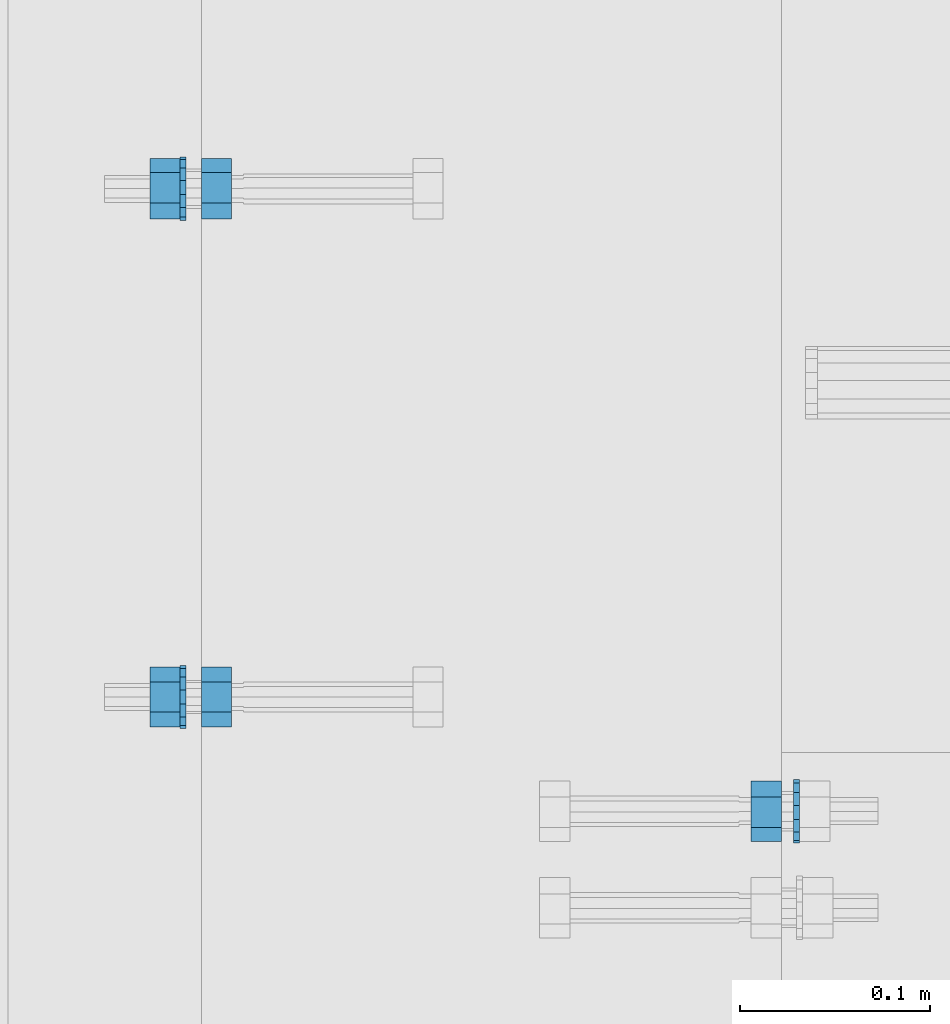
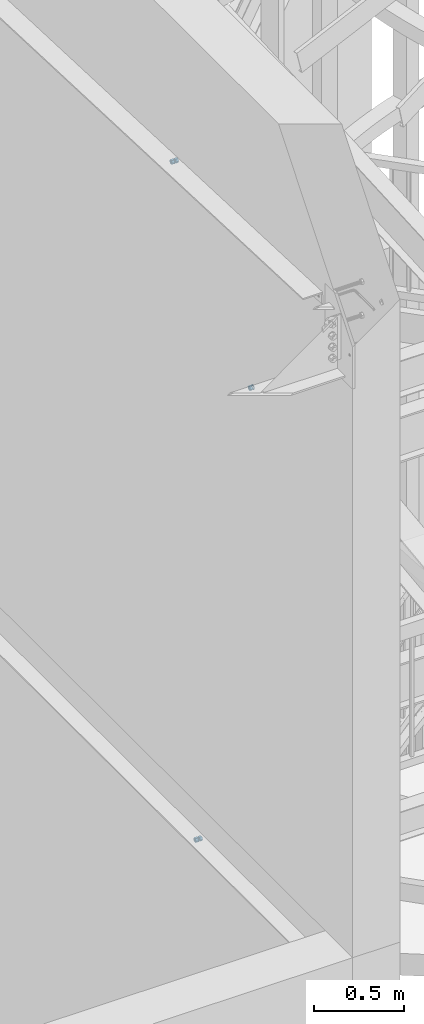
# One storey, part 641 of 975: 8 beams.
"""IFC2X3 building model written with IfcOpenShell, lengths in millimetres."""

from ifc_helpers import new_model, si_unit, frame, origin_with_axes, place, context, subcontext, project, spatial, faceted_brep, material, type_object, element, save


model = new_model("IFC2X3")

# Units and contexts
model_context = context("Model", 3, precision=1e-05, world=origin_with_axes())
body_context = subcontext(model_context, "Body", "Model", "MODEL_VIEW")
ifc_project = project(units=[si_unit("LENGTHUNIT", "METRE", prefix="MILLI"), si_unit("AREAUNIT", "SQUARE_METRE"), si_unit("VOLUMEUNIT", "CUBIC_METRE"), si_unit("MASSUNIT", "GRAM", prefix="KILO"), si_unit("TIMEUNIT", "SECOND"), si_unit("PLANEANGLEUNIT", "RADIAN"), si_unit("SOLIDANGLEUNIT", "STERADIAN"), si_unit("THERMODYNAMICTEMPERATUREUNIT", "DEGREE_CELSIUS"), si_unit("LUMINOUSINTENSITYUNIT", "LUMEN")], contexts=[model_context])

# Site, building, storey
site_placement = place(None, origin_with_axes())
site = spatial("IfcSite", under=ifc_project, at=site_placement, CompositionType="ELEMENT")
building_placement = place(site_placement, origin_with_axes())
building = spatial("IfcBuilding", under=site, at=building_placement, Name="Undefined", CompositionType="ELEMENT")
storey_placement = place(building_placement, origin_with_axes())
storey = spatial("IfcBuildingStorey", under=building, at=storey_placement, Name="Undefined", CompositionType="ELEMENT", Elevation=0.0)

# Beams
ifc_material_1 = material(Name="STEEL/F1554-36")
beam_type_1 = type_object("IfcBeamType", Name="5/8_HEAVY_HEX_NUT", PredefinedType="NOTDEFINED")
beam_1_placement = place(storey_placement, frame((29959.2998508932, 1654.53464347883, 6890.8904457363), z_axis=(3.96407267544419e-09, 0.0430877640020053, -0.999071291046494), x_axis=(-0.999999999999998, 6.90000001668524e-08, 0.0)))
element("IfcBeam", 1, at=beam_1_placement, inside=storey, type_object=beam_type_1, material=ifc_material_1, Name="HEADED_ANCHOR_BOLT", ObjectType="5/8_HEAVY_HEX_NUT", context=body_context, shape_type="Brep", body=[
    faceted_brep([(-1.09139364212751e-11, -15.8800001144436, -2.72848410531878e-12), (1.45519152283669e-11, -7.94000005722046, -13.7500000000036), (15.8750000000146, -7.94000005722137, -13.7500000000045), (15.8749999999891, -15.8800001144446, -2.72848410531878e-12), (2.91038304567337e-11, 7.94000005722319, -13.7500000000027), (15.8750000000291, 7.94000005722319, -13.7500000000027), (2.18278728425503e-11, 15.8800001144436, 9.09494701772928e-13), (15.8750000000218, 15.8800001144427, 9.09494701772928e-13), (-7.27595761418343e-12, 7.94000005722046, 13.7500000000027), (15.8749999999927, 7.94000005722046, 13.7500000000027), (-2.18278728425503e-11, -7.94000005722228, 13.7500000000009), (15.8749999999782, -7.94000005722319, 13.7500000000009), (-7.27595761418343e-12, 0.0, 8.72999954223724), (0.0, 3.78780484388062, 7.86545780435881), (15.875, 3.78780484387971, 7.86545780435881), (15.8749999999927, -9.09494701772928e-13, 8.72999954223724), (7.27595761418343e-12, 6.82538848405238, 5.44306568481716), (15.8750000000073, 6.82538848405238, 5.44306568481716), (1.09139364212751e-11, 8.51112022706275, 1.94260765157742), (15.8750000000109, 8.51112022706093, 1.94260765157651), (1.45519152283669e-11, 8.51112022706184, -1.94260765157651), (15.8750000000146, 8.51112022706184, -1.94260765157651), (2.18278728425503e-11, 6.8253884840542, -5.44306568481716), (15.8750000000218, 6.82538848405238, -5.44306568481716), (1.81898940354586e-11, 3.78780484388153, -7.86545780435881), (15.8750000000182, 3.78780484388062, -7.86545780435881), (1.81898940354586e-11, 9.09494701772928e-13, -8.72999954223997), (15.8750000000182, 9.09494701772928e-13, -8.72999954223997), (1.09139364212751e-11, -3.78780484387971, -7.86545780436063), (15.8750000000109, -3.78780484388062, -7.86545780436063), (3.63797880709171e-12, -6.82538848405238, -5.44306568481807), (15.8750000000036, -6.82538848405329, -5.44306568481807), (0.0, -8.51112022706184, -1.94260765157833), (15.875, -8.51112022706184, -1.94260765157833), (-7.27595761418343e-12, -8.51112022706184, 1.9426076515756), (15.8749999999927, -8.51112022706275, 1.9426076515756), (-1.09139364212751e-11, -6.82538848405329, 5.44306568481534), (15.8749999999927, -6.8253884840542, 5.44306568481534), (-7.27595761418343e-12, -3.78780484388062, 7.8654578043579), (15.8749999999927, -3.78780484388153, 7.8654578043579)], [[[0, 1, 2, 3]], [[1, 4, 5, 2]], [[4, 6, 7, 5]], [[6, 8, 9, 7]], [[8, 10, 11, 9]], [[10, 0, 3, 11]], [[12, 13, 14, 15]], [[13, 16, 17, 14]], [[16, 18, 19, 17]], [[18, 20, 21, 19]], [[20, 22, 23, 21]], [[22, 24, 25, 23]], [[24, 26, 27, 25]], [[26, 28, 29, 27]], [[28, 30, 31, 29]], [[30, 32, 33, 31]], [[32, 34, 35, 33]], [[34, 36, 37, 35]], [[36, 38, 39, 37]], [[38, 12, 15, 39]], [[5, 7, 9, 11, 3, 2], [17, 19, 21, 23, 25, 27, 29, 31, 33, 35, 37, 39, 15, 14]], [[10, 8, 6, 4, 1, 0], [38, 36, 34, 32, 30, 28, 26, 24, 22, 20, 18, 16, 13, 12]]]),
])
beam_2_placement = place(storey_placement, frame((29654.4998194947, 1981.48145341158, 8344.2911101487), z_axis=(-7.38476228434593e-09, 0.0401345820029659, 0.999194283073841), x_axis=(1.0, 0.0, 0.0)))
element("IfcBeam", 2, at=beam_2_placement, inside=storey, type_object=beam_type_1, material=ifc_material_1, Name="HEADED_ANCHOR_BOLT", ObjectType="5/8_HEAVY_HEX_NUT", context=body_context, shape_type="Brep", body=[
    faceted_brep([(-1.09139364212751e-11, -15.8800001144436, -2.72848410531878e-12), (1.45519152283669e-11, -7.94000005722046, -13.7500000000036), (15.8750000000146, -7.94000005722137, -13.7500000000045), (15.8749999999891, -15.8800001144446, -2.72848410531878e-12), (2.91038304567337e-11, 7.94000005722319, -13.7500000000027), (15.8750000000291, 7.94000005722319, -13.7500000000027), (2.18278728425503e-11, 15.8800001144436, 9.09494701772928e-13), (15.8750000000218, 15.8800001144427, 9.09494701772928e-13), (-7.27595761418343e-12, 7.94000005722046, 13.7500000000027), (15.8749999999927, 7.94000005722046, 13.7500000000027), (-2.18278728425503e-11, -7.94000005722228, 13.7500000000009), (15.8749999999782, -7.94000005722319, 13.7500000000009), (-7.27595761418343e-12, 0.0, 8.72999954223724), (0.0, 3.78780484388062, 7.86545780435881), (15.875, 3.78780484387971, 7.86545780435881), (15.8749999999927, -9.09494701772928e-13, 8.72999954223724), (7.27595761418343e-12, 6.82538848405238, 5.44306568481716), (15.8750000000073, 6.82538848405238, 5.44306568481716), (1.09139364212751e-11, 8.51112022706275, 1.94260765157742), (15.8750000000109, 8.51112022706093, 1.94260765157651), (1.45519152283669e-11, 8.51112022706184, -1.94260765157651), (15.8750000000146, 8.51112022706184, -1.94260765157651), (2.18278728425503e-11, 6.8253884840542, -5.44306568481716), (15.8750000000218, 6.82538848405238, -5.44306568481716), (1.81898940354586e-11, 3.78780484388153, -7.86545780435881), (15.8750000000182, 3.78780484388062, -7.86545780435881), (1.81898940354586e-11, 9.09494701772928e-13, -8.72999954223997), (15.8750000000182, 9.09494701772928e-13, -8.72999954223997), (1.09139364212751e-11, -3.78780484387971, -7.86545780436063), (15.8750000000109, -3.78780484388062, -7.86545780436063), (3.63797880709171e-12, -6.82538848405238, -5.44306568481807), (15.8750000000036, -6.82538848405329, -5.44306568481807), (0.0, -8.51112022706184, -1.94260765157833), (15.875, -8.51112022706184, -1.94260765157833), (-7.27595761418343e-12, -8.51112022706184, 1.9426076515756), (15.8749999999927, -8.51112022706275, 1.9426076515756), (-1.09139364212751e-11, -6.82538848405329, 5.44306568481534), (15.8749999999927, -6.8253884840542, 5.44306568481534), (-7.27595761418343e-12, -3.78780484388062, 7.8654578043579), (15.8749999999927, -3.78780484388153, 7.8654578043579)], [[[0, 1, 2, 3]], [[1, 4, 5, 2]], [[4, 6, 7, 5]], [[6, 8, 9, 7]], [[8, 10, 11, 9]], [[10, 0, 3, 11]], [[12, 13, 14, 15]], [[13, 16, 17, 14]], [[16, 18, 19, 17]], [[18, 20, 21, 19]], [[20, 22, 23, 21]], [[22, 24, 25, 23]], [[24, 26, 27, 25]], [[26, 28, 29, 27]], [[28, 30, 31, 29]], [[30, 32, 33, 31]], [[32, 34, 35, 33]], [[34, 36, 37, 35]], [[36, 38, 39, 37]], [[38, 12, 15, 39]], [[5, 7, 9, 11, 3, 2], [17, 19, 21, 23, 25, 27, 29, 31, 33, 35, 37, 39, 15, 14]], [[10, 8, 6, 4, 1, 0], [38, 36, 34, 32, 30, 28, 26, 24, 22, 20, 18, 16, 13, 12]]]),
])
beam_3_placement = place(storey_placement, frame((29627.5123194944, 1981.48144848359, 8344.29111018868), z_axis=(-7.38476228434593e-09, 0.0401345820029659, 0.999194283073841), x_axis=(1.0, 0.0, 0.0)))
element("IfcBeam", 3, at=beam_3_placement, inside=storey, type_object=beam_type_1, material=ifc_material_1, Name="HEADED_ANCHOR_BOLT", ObjectType="5/8_HEAVY_HEX_NUT", context=body_context, shape_type="Brep", body=[
    faceted_brep([(-1.09139364212751e-11, -15.8800001144436, -2.72848410531878e-12), (1.45519152283669e-11, -7.94000005722046, -13.7500000000036), (15.8750000000146, -7.94000005722137, -13.7500000000045), (15.8749999999891, -15.8800001144446, -2.72848410531878e-12), (2.91038304567337e-11, 7.94000005722319, -13.7500000000027), (15.8750000000291, 7.94000005722319, -13.7500000000027), (2.18278728425503e-11, 15.8800001144436, 9.09494701772928e-13), (15.8750000000218, 15.8800001144427, 9.09494701772928e-13), (-7.27595761418343e-12, 7.94000005722046, 13.7500000000027), (15.8749999999927, 7.94000005722046, 13.7500000000027), (-2.18278728425503e-11, -7.94000005722228, 13.7500000000009), (15.8749999999782, -7.94000005722319, 13.7500000000009), (-7.27595761418343e-12, 0.0, 8.72999954223724), (0.0, 3.78780484388062, 7.86545780435881), (15.875, 3.78780484387971, 7.86545780435881), (15.8749999999927, -9.09494701772928e-13, 8.72999954223724), (7.27595761418343e-12, 6.82538848405238, 5.44306568481716), (15.8750000000073, 6.82538848405238, 5.44306568481716), (1.09139364212751e-11, 8.51112022706275, 1.94260765157742), (15.8750000000109, 8.51112022706093, 1.94260765157651), (1.45519152283669e-11, 8.51112022706184, -1.94260765157651), (15.8750000000146, 8.51112022706184, -1.94260765157651), (2.18278728425503e-11, 6.8253884840542, -5.44306568481716), (15.8750000000218, 6.82538848405238, -5.44306568481716), (1.81898940354586e-11, 3.78780484388153, -7.86545780435881), (15.8750000000182, 3.78780484388062, -7.86545780435881), (1.81898940354586e-11, 9.09494701772928e-13, -8.72999954223997), (15.8750000000182, 9.09494701772928e-13, -8.72999954223997), (1.09139364212751e-11, -3.78780484387971, -7.86545780436063), (15.8750000000109, -3.78780484388062, -7.86545780436063), (3.63797880709171e-12, -6.82538848405238, -5.44306568481807), (15.8750000000036, -6.82538848405329, -5.44306568481807), (0.0, -8.51112022706184, -1.94260765157833), (15.875, -8.51112022706184, -1.94260765157833), (-7.27595761418343e-12, -8.51112022706184, 1.9426076515756), (15.8749999999927, -8.51112022706275, 1.9426076515756), (-1.09139364212751e-11, -6.82538848405329, 5.44306568481534), (15.8749999999927, -6.8253884840542, 5.44306568481534), (-7.27595761418343e-12, -3.78780484388062, 7.8654578043579), (15.8749999999927, -3.78780484388153, 7.8654578043579)], [[[0, 1, 2, 3]], [[1, 4, 5, 2]], [[4, 6, 7, 5]], [[6, 8, 9, 7]], [[8, 10, 11, 9]], [[10, 0, 3, 11]], [[12, 13, 14, 15]], [[13, 16, 17, 14]], [[16, 18, 19, 17]], [[18, 20, 21, 19]], [[20, 22, 23, 21]], [[22, 24, 25, 23]], [[24, 26, 27, 25]], [[26, 28, 29, 27]], [[28, 30, 31, 29]], [[30, 32, 33, 31]], [[32, 34, 35, 33]], [[34, 36, 37, 35]], [[36, 38, 39, 37]], [[38, 12, 15, 39]], [[5, 7, 9, 11, 3, 2], [17, 19, 21, 23, 25, 27, 29, 31, 33, 35, 37, 39, 15, 14]], [[10, 8, 6, 4, 1, 0], [38, 36, 34, 32, 30, 28, 26, 24, 22, 20, 18, 16, 13, 12]]]),
])
ifc_material_2 = material(Name="STEEL/A36")
beam_4_placement = place(storey_placement, frame((29654.4998261983, 1714.50037385659, 3886.2), z_axis=(0.0, 0.0, 1.0), x_axis=(1.0, 0.0, 0.0)))
element("IfcBeam", 4, at=beam_4_placement, inside=storey, type_object=beam_type_1, material=ifc_material_2, Name="NUT", ObjectType="5/8_HEAVY_HEX_NUT", context=body_context, shape_type="Brep", body=[
    faceted_brep([(-1.09139364212751e-11, -15.8800001144436, -2.72848410531878e-12), (1.45519152283669e-11, -7.94000005722046, -13.7500000000036), (15.8750000000146, -7.94000005722137, -13.7500000000045), (15.8749999999891, -15.8800001144446, -2.72848410531878e-12), (2.91038304567337e-11, 7.94000005722319, -13.7500000000027), (15.8750000000291, 7.94000005722319, -13.7500000000027), (2.18278728425503e-11, 15.8800001144436, 9.09494701772928e-13), (15.8750000000218, 15.8800001144427, 9.09494701772928e-13), (-7.27595761418343e-12, 7.94000005722046, 13.7500000000027), (15.8749999999927, 7.94000005722046, 13.7500000000027), (-2.18278728425503e-11, -7.94000005722228, 13.7500000000009), (15.8749999999782, -7.94000005722319, 13.7500000000009), (-7.27595761418343e-12, 0.0, 8.72999954223724), (0.0, 3.78780484388062, 7.86545780435881), (15.875, 3.78780484387971, 7.86545780435881), (15.8749999999927, -9.09494701772928e-13, 8.72999954223724), (7.27595761418343e-12, 6.82538848405238, 5.44306568481716), (15.8750000000073, 6.82538848405238, 5.44306568481716), (1.09139364212751e-11, 8.51112022706275, 1.94260765157742), (15.8750000000109, 8.51112022706093, 1.94260765157651), (1.45519152283669e-11, 8.51112022706184, -1.94260765157651), (15.8750000000146, 8.51112022706184, -1.94260765157651), (2.18278728425503e-11, 6.8253884840542, -5.44306568481716), (15.8750000000218, 6.82538848405238, -5.44306568481716), (1.81898940354586e-11, 3.78780484388153, -7.86545780435881), (15.8750000000182, 3.78780484388062, -7.86545780435881), (1.81898940354586e-11, 9.09494701772928e-13, -8.72999954223997), (15.8750000000182, 9.09494701772928e-13, -8.72999954223997), (1.09139364212751e-11, -3.78780484387971, -7.86545780436063), (15.8750000000109, -3.78780484388062, -7.86545780436063), (3.63797880709171e-12, -6.82538848405238, -5.44306568481807), (15.8750000000036, -6.82538848405329, -5.44306568481807), (0.0, -8.51112022706184, -1.94260765157833), (15.875, -8.51112022706184, -1.94260765157833), (-7.27595761418343e-12, -8.51112022706184, 1.9426076515756), (15.8749999999927, -8.51112022706275, 1.9426076515756), (-1.09139364212751e-11, -6.82538848405329, 5.44306568481534), (15.8749999999927, -6.8253884840542, 5.44306568481534), (-7.27595761418343e-12, -3.78780484388062, 7.8654578043579), (15.8749999999927, -3.78780484388153, 7.8654578043579)], [[[0, 1, 2, 3]], [[1, 4, 5, 2]], [[4, 6, 7, 5]], [[6, 8, 9, 7]], [[8, 10, 11, 9]], [[10, 0, 3, 11]], [[12, 13, 14, 15]], [[13, 16, 17, 14]], [[16, 18, 19, 17]], [[18, 20, 21, 19]], [[20, 22, 23, 21]], [[22, 24, 25, 23]], [[24, 26, 27, 25]], [[26, 28, 29, 27]], [[28, 30, 31, 29]], [[30, 32, 33, 31]], [[32, 34, 35, 33]], [[34, 36, 37, 35]], [[36, 38, 39, 37]], [[38, 12, 15, 39]], [[5, 7, 9, 11, 3, 2], [17, 19, 21, 23, 25, 27, 29, 31, 33, 35, 37, 39, 15, 14]], [[10, 8, 6, 4, 1, 0], [38, 36, 34, 32, 30, 28, 26, 24, 22, 20, 18, 16, 13, 12]]]),
])
beam_5_placement = place(storey_placement, frame((29627.5123261983, 1714.50037385659, 3886.2), z_axis=(0.0, 0.0, 1.0), x_axis=(1.0, 0.0, 0.0)))
element("IfcBeam", 5, at=beam_5_placement, inside=storey, type_object=beam_type_1, material=ifc_material_2, Name="NUT", ObjectType="5/8_HEAVY_HEX_NUT", context=body_context, shape_type="Brep", body=[
    faceted_brep([(-1.09139364212751e-11, -15.8800001144436, -2.72848410531878e-12), (1.45519152283669e-11, -7.94000005722046, -13.7500000000036), (15.8750000000146, -7.94000005722137, -13.7500000000045), (15.8749999999891, -15.8800001144446, -2.72848410531878e-12), (2.91038304567337e-11, 7.94000005722319, -13.7500000000027), (15.8750000000291, 7.94000005722319, -13.7500000000027), (2.18278728425503e-11, 15.8800001144436, 9.09494701772928e-13), (15.8750000000218, 15.8800001144427, 9.09494701772928e-13), (-7.27595761418343e-12, 7.94000005722046, 13.7500000000027), (15.8749999999927, 7.94000005722046, 13.7500000000027), (-2.18278728425503e-11, -7.94000005722228, 13.7500000000009), (15.8749999999782, -7.94000005722319, 13.7500000000009), (-7.27595761418343e-12, 0.0, 8.72999954223724), (0.0, 3.78780484388062, 7.86545780435881), (15.875, 3.78780484387971, 7.86545780435881), (15.8749999999927, -9.09494701772928e-13, 8.72999954223724), (7.27595761418343e-12, 6.82538848405238, 5.44306568481716), (15.8750000000073, 6.82538848405238, 5.44306568481716), (1.09139364212751e-11, 8.51112022706275, 1.94260765157742), (15.8750000000109, 8.51112022706093, 1.94260765157651), (1.45519152283669e-11, 8.51112022706184, -1.94260765157651), (15.8750000000146, 8.51112022706184, -1.94260765157651), (2.18278728425503e-11, 6.8253884840542, -5.44306568481716), (15.8750000000218, 6.82538848405238, -5.44306568481716), (1.81898940354586e-11, 3.78780484388153, -7.86545780435881), (15.8750000000182, 3.78780484388062, -7.86545780435881), (1.81898940354586e-11, 9.09494701772928e-13, -8.72999954223997), (15.8750000000182, 9.09494701772928e-13, -8.72999954223997), (1.09139364212751e-11, -3.78780484387971, -7.86545780436063), (15.8750000000109, -3.78780484388062, -7.86545780436063), (3.63797880709171e-12, -6.82538848405238, -5.44306568481807), (15.8750000000036, -6.82538848405329, -5.44306568481807), (0.0, -8.51112022706184, -1.94260765157833), (15.875, -8.51112022706184, -1.94260765157833), (-7.27595761418343e-12, -8.51112022706184, 1.9426076515756), (15.8749999999927, -8.51112022706275, 1.9426076515756), (-1.09139364212751e-11, -6.82538848405329, 5.44306568481534), (15.8749999999927, -6.8253884840542, 5.44306568481534), (-7.27595761418343e-12, -3.78780484388062, 7.8654578043579), (15.8749999999927, -3.78780484388153, 7.8654578043579)], [[[0, 1, 2, 3]], [[1, 4, 5, 2]], [[4, 6, 7, 5]], [[6, 8, 9, 7]], [[8, 10, 11, 9]], [[10, 0, 3, 11]], [[12, 13, 14, 15]], [[13, 16, 17, 14]], [[16, 18, 19, 17]], [[18, 20, 21, 19]], [[20, 22, 23, 21]], [[22, 24, 25, 23]], [[24, 26, 27, 25]], [[26, 28, 29, 27]], [[28, 30, 31, 29]], [[30, 32, 33, 31]], [[32, 34, 35, 33]], [[34, 36, 37, 35]], [[36, 38, 39, 37]], [[38, 12, 15, 39]], [[5, 7, 9, 11, 3, 2], [17, 19, 21, 23, 25, 27, 29, 31, 33, 35, 37, 39, 15, 14]], [[10, 8, 6, 4, 1, 0], [38, 36, 34, 32, 30, 28, 26, 24, 22, 20, 18, 16, 13, 12]]]),
])
beam_type_2 = type_object("IfcBeamType", Name="5/8_WASHER", PredefinedType="NOTDEFINED")
beam_6_placement = place(storey_placement, frame((29968.8248520217, 1654.53464256924, 6890.8904456672), z_axis=(3.96407267544419e-09, 0.0430877640020053, -0.999071291046494), x_axis=(-0.999999999999998, 6.90000001668524e-08, 0.0)))
element("IfcBeam", 6, at=beam_6_placement, inside=storey, type_object=beam_type_2, material=ifc_material_1, Name="HEADED_ANCHOR_BOLT", ObjectType="5/8_WASHER", context=body_context, shape_type="Brep", body=[
    faceted_brep([(1.09139364212751e-11, -16.670000076293, -2.72848410531878e-12), (2.18278728425503e-11, -15.0191510966704, -7.23284196419536), (3.1750000000211, -15.0191510966711, -7.23284196419627), (3.17500000001019, -16.6700000762937, -1.81898940354586e-12), (2.91038304567337e-11, -10.3935750445523, -13.0331308723944), (3.17500000002838, -10.3935750445526, -13.0331308723953), (2.91038304567337e-11, -3.70942398602756, -16.2520483704566), (3.17500000002838, -3.70942398602779, -16.2520483704566), (2.5465851649642e-11, 3.70942398602961, -16.2520483704557), (3.17500000002474, 3.70942398602961, -16.2520483704566), (1.45519152283669e-11, 10.3935750445542, -13.0331308723935), (3.17500000001382, 10.3935750445537, -13.0331308723944), (0.0, 15.0191510966717, -7.23284196419354), (3.17499999999927, 15.0191510966713, -7.23284196419354), (-7.27595761418343e-12, 16.6700000762933, 0.0), (3.174999999992, 16.6700000762928, -9.09494701772928e-13), (-1.81898940354586e-11, 15.0191510966706, 7.23284196419354), (3.17499999998108, 15.0191510966704, 7.23284196419354), (-2.5465851649642e-11, 10.3935750445519, 13.0331308723926), (3.17499999997381, 10.3935750445517, 13.0331308723926), (-2.5465851649642e-11, 3.70942398602733, 16.2520483704538), (3.17499999997381, 3.7094239860271, 16.2520483704529), (-2.18278728425503e-11, -3.70942398602983, 16.2520483704529), (3.17499999997744, -3.70942398603006, 16.2520483704538), (-1.09139364212751e-11, -10.3935750445542, 13.0331308723908), (3.17499999998836, -10.3935750445544, 13.0331308723908), (0.0, -15.0191510966717, 7.23284196419172), (3.17499999999927, -15.019151096672, 7.23284196419081), (-7.27595761418343e-12, 0.0, 8.72999954223724), (0.0, 3.78780484388062, 7.86545780435881), (3.17499999998472, 3.78780484387903, 7.86545780435699), (3.17499999998836, -9.09494701772928e-13, 8.72999954223542), (7.27595761418343e-12, 6.82538848405238, 5.44306568481716), (3.17499999998836, 6.82538848405102, 5.44306568481534), (1.09139364212751e-11, 8.51112022706275, 1.94260765157742), (3.174999999992, 8.51112022705979, 1.94260765157651), (1.45519152283669e-11, 8.51112022706184, -1.94260765157651), (3.17499999999563, 8.51112022706025, -1.94260765157742), (2.18278728425503e-11, 6.8253884840542, -5.44306568481716), (3.17500000000655, 6.8253884840517, -5.44306568481807), (1.81898940354586e-11, 3.78780484388153, -7.86545780435881), (3.17500000001019, 3.78780484388017, -7.86545780435972), (1.81898940354586e-11, 9.09494701772928e-13, -8.72999954223997), (3.17500000001382, 6.82121026329696e-13, -8.72999954223997), (1.09139364212751e-11, -3.78780484387971, -7.86545780436063), (3.17500000001382, -3.78780484387994, -7.86545780436063), (3.63797880709171e-12, -6.82538848405238, -5.44306568481807), (3.17500000001019, -6.82538848405147, -5.44306568481898), (0.0, -8.51112022706184, -1.94260765157833), (3.17500000001019, -8.5111202270607, -1.94260765157924), (-7.27595761418343e-12, -8.51112022706184, 1.9426076515756), (3.17500000000291, -8.51112022706093, 1.94260765157469), (-1.09139364212751e-11, -6.82538848405329, 5.44306568481534), (3.17499999999563, -6.82538848405238, 5.44306568481534), (-7.27595761418343e-12, -3.78780484388062, 7.8654578043579), (3.174999999992, -3.78780484388085, 7.86545780435699)], [[[0, 1, 2, 3]], [[1, 4, 5, 2]], [[4, 6, 7, 5]], [[6, 8, 9, 7]], [[8, 10, 11, 9]], [[10, 12, 13, 11]], [[12, 14, 15, 13]], [[14, 16, 17, 15]], [[16, 18, 19, 17]], [[18, 20, 21, 19]], [[20, 22, 23, 21]], [[22, 24, 25, 23]], [[24, 26, 27, 25]], [[26, 0, 3, 27]], [[28, 29, 30, 31]], [[29, 32, 33, 30]], [[32, 34, 35, 33]], [[34, 36, 37, 35]], [[36, 38, 39, 37]], [[38, 40, 41, 39]], [[40, 42, 43, 41]], [[42, 44, 45, 43]], [[44, 46, 47, 45]], [[46, 48, 49, 47]], [[48, 50, 51, 49]], [[50, 52, 53, 51]], [[52, 54, 55, 53]], [[54, 28, 31, 55]], [[5, 7, 9, 11, 13, 15, 17, 19, 21, 23, 25, 27, 3, 2], [33, 35, 37, 39, 41, 43, 45, 47, 49, 51, 53, 55, 31, 30]], [[26, 24, 22, 20, 18, 16, 14, 12, 10, 8, 6, 4, 1, 0], [54, 52, 50, 48, 46, 44, 42, 40, 38, 36, 34, 32, 29, 28]]]),
])
beam_7_placement = place(storey_placement, frame((29643.3873194942, 1981.48145143731, 8344.29111021502), z_axis=(-7.38476228434593e-09, 0.0401345820029659, 0.999194283073841), x_axis=(1.0, 0.0, 0.0)))
element("IfcBeam", 7, at=beam_7_placement, inside=storey, type_object=beam_type_2, material=ifc_material_1, Name="HEADED_ANCHOR_BOLT", ObjectType="5/8_WASHER", context=body_context, shape_type="Brep", body=[
    faceted_brep([(1.09139364212751e-11, -16.670000076293, -2.72848410531878e-12), (2.18278728425503e-11, -15.0191510966704, -7.23284196419536), (3.1750000000211, -15.0191510966711, -7.23284196419627), (3.17500000001019, -16.6700000762937, -1.81898940354586e-12), (2.91038304567337e-11, -10.3935750445523, -13.0331308723944), (3.17500000002838, -10.3935750445526, -13.0331308723953), (2.91038304567337e-11, -3.70942398602756, -16.2520483704566), (3.17500000002838, -3.70942398602779, -16.2520483704566), (2.5465851649642e-11, 3.70942398602961, -16.2520483704557), (3.17500000002474, 3.70942398602961, -16.2520483704566), (1.45519152283669e-11, 10.3935750445542, -13.0331308723935), (3.17500000001382, 10.3935750445537, -13.0331308723944), (0.0, 15.0191510966717, -7.23284196419354), (3.17499999999927, 15.0191510966713, -7.23284196419354), (-7.27595761418343e-12, 16.6700000762933, 0.0), (3.174999999992, 16.6700000762928, -9.09494701772928e-13), (-1.81898940354586e-11, 15.0191510966706, 7.23284196419354), (3.17499999998108, 15.0191510966704, 7.23284196419354), (-2.5465851649642e-11, 10.3935750445519, 13.0331308723926), (3.17499999997381, 10.3935750445517, 13.0331308723926), (-2.5465851649642e-11, 3.70942398602733, 16.2520483704538), (3.17499999997381, 3.7094239860271, 16.2520483704529), (-2.18278728425503e-11, -3.70942398602983, 16.2520483704529), (3.17499999997744, -3.70942398603006, 16.2520483704538), (-1.09139364212751e-11, -10.3935750445542, 13.0331308723908), (3.17499999998836, -10.3935750445544, 13.0331308723908), (0.0, -15.0191510966717, 7.23284196419172), (3.17499999999927, -15.019151096672, 7.23284196419081), (-7.27595761418343e-12, 0.0, 8.72999954223724), (0.0, 3.78780484388062, 7.86545780435881), (3.17499999998472, 3.78780484387903, 7.86545780435699), (3.17499999998836, -9.09494701772928e-13, 8.72999954223542), (7.27595761418343e-12, 6.82538848405238, 5.44306568481716), (3.17499999998836, 6.82538848405102, 5.44306568481534), (1.09139364212751e-11, 8.51112022706275, 1.94260765157742), (3.174999999992, 8.51112022705979, 1.94260765157651), (1.45519152283669e-11, 8.51112022706184, -1.94260765157651), (3.17499999999563, 8.51112022706025, -1.94260765157742), (2.18278728425503e-11, 6.8253884840542, -5.44306568481716), (3.17500000000655, 6.8253884840517, -5.44306568481807), (1.81898940354586e-11, 3.78780484388153, -7.86545780435881), (3.17500000001019, 3.78780484388017, -7.86545780435972), (1.81898940354586e-11, 9.09494701772928e-13, -8.72999954223997), (3.17500000001382, 6.82121026329696e-13, -8.72999954223997), (1.09139364212751e-11, -3.78780484387971, -7.86545780436063), (3.17500000001382, -3.78780484387994, -7.86545780436063), (3.63797880709171e-12, -6.82538848405238, -5.44306568481807), (3.17500000001019, -6.82538848405147, -5.44306568481898), (0.0, -8.51112022706184, -1.94260765157833), (3.17500000001019, -8.5111202270607, -1.94260765157924), (-7.27595761418343e-12, -8.51112022706184, 1.9426076515756), (3.17500000000291, -8.51112022706093, 1.94260765157469), (-1.09139364212751e-11, -6.82538848405329, 5.44306568481534), (3.17499999999563, -6.82538848405238, 5.44306568481534), (-7.27595761418343e-12, -3.78780484388062, 7.8654578043579), (3.174999999992, -3.78780484388085, 7.86545780435699)], [[[0, 1, 2, 3]], [[1, 4, 5, 2]], [[4, 6, 7, 5]], [[6, 8, 9, 7]], [[8, 10, 11, 9]], [[10, 12, 13, 11]], [[12, 14, 15, 13]], [[14, 16, 17, 15]], [[16, 18, 19, 17]], [[18, 20, 21, 19]], [[20, 22, 23, 21]], [[22, 24, 25, 23]], [[24, 26, 27, 25]], [[26, 0, 3, 27]], [[28, 29, 30, 31]], [[29, 32, 33, 30]], [[32, 34, 35, 33]], [[34, 36, 37, 35]], [[36, 38, 39, 37]], [[38, 40, 41, 39]], [[40, 42, 43, 41]], [[42, 44, 45, 43]], [[44, 46, 47, 45]], [[46, 48, 49, 47]], [[48, 50, 51, 49]], [[50, 52, 53, 51]], [[52, 54, 55, 53]], [[54, 28, 31, 55]], [[5, 7, 9, 11, 13, 15, 17, 19, 21, 23, 25, 27, 3, 2], [33, 35, 37, 39, 41, 43, 45, 47, 49, 51, 53, 55, 31, 30]], [[26, 24, 22, 20, 18, 16, 14, 12, 10, 8, 6, 4, 1, 0], [54, 52, 50, 48, 46, 44, 42, 40, 38, 36, 34, 32, 29, 28]]]),
])
beam_8_placement = place(storey_placement, frame((29643.3873261983, 1714.50037385659, 3886.2), z_axis=(0.0, 0.0, 1.0), x_axis=(1.0, 0.0, 0.0)))
element("IfcBeam", 8, at=beam_8_placement, inside=storey, type_object=beam_type_2, material=ifc_material_2, Name="WASHER", ObjectType="5/8_WASHER", context=body_context, shape_type="Brep", body=[
    faceted_brep([(1.09139364212751e-11, -16.670000076293, -2.72848410531878e-12), (2.18278728425503e-11, -15.0191510966704, -7.23284196419536), (3.1750000000211, -15.0191510966711, -7.23284196419627), (3.17500000001019, -16.6700000762937, -1.81898940354586e-12), (2.91038304567337e-11, -10.3935750445523, -13.0331308723944), (3.17500000002838, -10.3935750445526, -13.0331308723953), (2.91038304567337e-11, -3.70942398602756, -16.2520483704566), (3.17500000002838, -3.70942398602779, -16.2520483704566), (2.5465851649642e-11, 3.70942398602961, -16.2520483704557), (3.17500000002474, 3.70942398602961, -16.2520483704566), (1.45519152283669e-11, 10.3935750445542, -13.0331308723935), (3.17500000001382, 10.3935750445537, -13.0331308723944), (0.0, 15.0191510966717, -7.23284196419354), (3.17499999999927, 15.0191510966713, -7.23284196419354), (-7.27595761418343e-12, 16.6700000762933, 0.0), (3.174999999992, 16.6700000762928, -9.09494701772928e-13), (-1.81898940354586e-11, 15.0191510966706, 7.23284196419354), (3.17499999998108, 15.0191510966704, 7.23284196419354), (-2.5465851649642e-11, 10.3935750445519, 13.0331308723926), (3.17499999997381, 10.3935750445517, 13.0331308723926), (-2.5465851649642e-11, 3.70942398602733, 16.2520483704538), (3.17499999997381, 3.7094239860271, 16.2520483704529), (-2.18278728425503e-11, -3.70942398602983, 16.2520483704529), (3.17499999997744, -3.70942398603006, 16.2520483704538), (-1.09139364212751e-11, -10.3935750445542, 13.0331308723908), (3.17499999998836, -10.3935750445544, 13.0331308723908), (0.0, -15.0191510966717, 7.23284196419172), (3.17499999999927, -15.019151096672, 7.23284196419081), (-7.27595761418343e-12, 0.0, 8.72999954223724), (0.0, 3.78780484388062, 7.86545780435881), (3.17499999998472, 3.78780484387903, 7.86545780435699), (3.17499999998836, -9.09494701772928e-13, 8.72999954223542), (7.27595761418343e-12, 6.82538848405238, 5.44306568481716), (3.17499999998836, 6.82538848405102, 5.44306568481534), (1.09139364212751e-11, 8.51112022706275, 1.94260765157742), (3.174999999992, 8.51112022705979, 1.94260765157651), (1.45519152283669e-11, 8.51112022706184, -1.94260765157651), (3.17499999999563, 8.51112022706025, -1.94260765157742), (2.18278728425503e-11, 6.8253884840542, -5.44306568481716), (3.17500000000655, 6.8253884840517, -5.44306568481807), (1.81898940354586e-11, 3.78780484388153, -7.86545780435881), (3.17500000001019, 3.78780484388017, -7.86545780435972), (1.81898940354586e-11, 9.09494701772928e-13, -8.72999954223997), (3.17500000001382, 6.82121026329696e-13, -8.72999954223997), (1.09139364212751e-11, -3.78780484387971, -7.86545780436063), (3.17500000001382, -3.78780484387994, -7.86545780436063), (3.63797880709171e-12, -6.82538848405238, -5.44306568481807), (3.17500000001019, -6.82538848405147, -5.44306568481898), (0.0, -8.51112022706184, -1.94260765157833), (3.17500000001019, -8.5111202270607, -1.94260765157924), (-7.27595761418343e-12, -8.51112022706184, 1.9426076515756), (3.17500000000291, -8.51112022706093, 1.94260765157469), (-1.09139364212751e-11, -6.82538848405329, 5.44306568481534), (3.17499999999563, -6.82538848405238, 5.44306568481534), (-7.27595761418343e-12, -3.78780484388062, 7.8654578043579), (3.174999999992, -3.78780484388085, 7.86545780435699)], [[[0, 1, 2, 3]], [[1, 4, 5, 2]], [[4, 6, 7, 5]], [[6, 8, 9, 7]], [[8, 10, 11, 9]], [[10, 12, 13, 11]], [[12, 14, 15, 13]], [[14, 16, 17, 15]], [[16, 18, 19, 17]], [[18, 20, 21, 19]], [[20, 22, 23, 21]], [[22, 24, 25, 23]], [[24, 26, 27, 25]], [[26, 0, 3, 27]], [[28, 29, 30, 31]], [[29, 32, 33, 30]], [[32, 34, 35, 33]], [[34, 36, 37, 35]], [[36, 38, 39, 37]], [[38, 40, 41, 39]], [[40, 42, 43, 41]], [[42, 44, 45, 43]], [[44, 46, 47, 45]], [[46, 48, 49, 47]], [[48, 50, 51, 49]], [[50, 52, 53, 51]], [[52, 54, 55, 53]], [[54, 28, 31, 55]], [[5, 7, 9, 11, 13, 15, 17, 19, 21, 23, 25, 27, 3, 2], [33, 35, 37, 39, 41, 43, 45, 47, 49, 51, 53, 55, 31, 30]], [[26, 24, 22, 20, 18, 16, 14, 12, 10, 8, 6, 4, 1, 0], [54, 52, 50, 48, 46, 44, 42, 40, 38, 36, 34, 32, 29, 28]]]),
])

save(model, "model.ifc")
